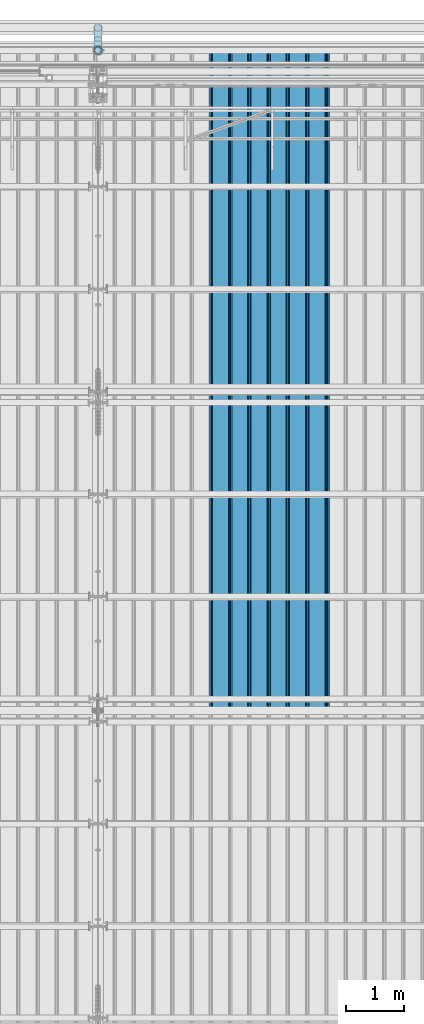
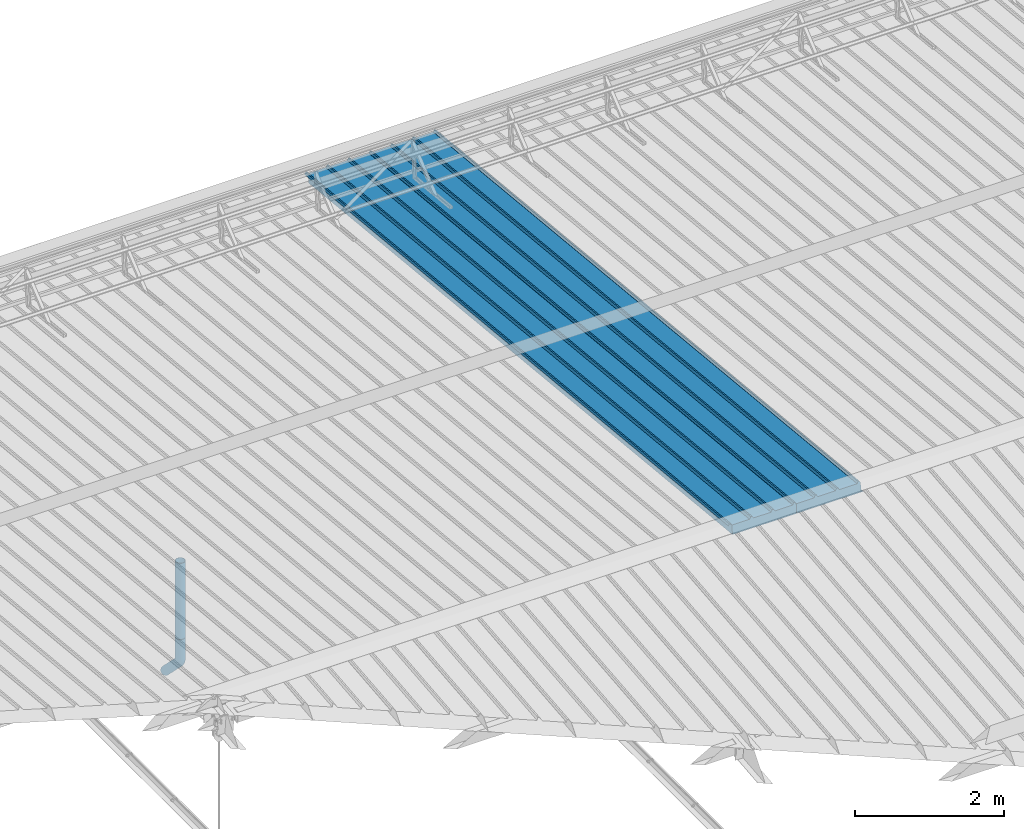
# One storey, part 60 of 709: 4 beams, 4 elements without a shape of their own.
"""IFC4 building model written with IfcOpenShell, lengths in millimetres."""

from ifc_helpers import new_model, entity, si_unit, direction, frame, origin_with_axes, place, context, subcontext, project, spatial, line, indexed_curve, outline, extrude, material, element, aggregate, save


model = new_model("IFC4")

# Units and contexts
model_context = context("Model", 3, precision=0.2, world=origin_with_axes(), true_north=direction((0.0, 1.0)))
body_context = subcontext(model_context, "Body", "Model", "MODEL_VIEW")
ifc_project = project(units=[si_unit("LENGTHUNIT", "METRE", prefix="MILLI"), si_unit("AREAUNIT", "SQUARE_METRE"), si_unit("VOLUMEUNIT", "CUBIC_METRE"), si_unit("MASSUNIT", "GRAM", prefix="KILO"), si_unit("TIMEUNIT", "SECOND"), si_unit("PLANEANGLEUNIT", "RADIAN"), si_unit("SOLIDANGLEUNIT", "STERADIAN"), si_unit("THERMODYNAMICTEMPERATUREUNIT", "DEGREE_CELSIUS"), si_unit("LUMINOUSINTENSITYUNIT", "LUMEN")], contexts=[model_context])

# Site, building, storey
site_placement = place(None, origin_with_axes())
site = spatial("IfcSite", under=ifc_project, at=site_placement, CompositionType="ELEMENT")
building_placement = place(site_placement, origin_with_axes())
building = spatial("IfcBuilding", under=site, at=building_placement, Name="Undefined", CompositionType="ELEMENT")
storey_placement = place(building_placement, origin_with_axes())
storey = spatial("IfcBuildingStorey", under=building, at=storey_placement, Name="Undefined", CompositionType="ELEMENT", Elevation=0.0)

# Assembly, beam
assembly_1_placement = place(storey_placement, frame((25452.44, 11009.10459, 8419.96887), z_axis=(1.0, 0.0, 0.0), x_axis=(0.0, 0.9950371902, -0.099503719)))
assembly_1 = element("IfcElementAssembly", 1, at=assembly_1_placement, inside=storey)
ifc_material_1 = material(Name="Insulation", Category="Insulation")
beam_1_placement = place(assembly_1_placement, origin_with_axes())
beam_1 = element("IfcBeam", 2, at=beam_1_placement, material=ifc_material_1, ObjectType="P-99", context=body_context, shape_type="SolidModel", body=[
    extrude(outline(indexed_curve([(-509.8453, 89.5), (-490.1547, 89.5), (-471.67949, 57.5), (-471.67949, -88.5), (-436.67949, -88.5), (-436.67949, -91.5), (562.55841, -91.5), (562.55841, -89.5), (527.55841, -89.5), (527.55841, 57.5), (510.2379, 88.5), (489.7621, 88.5), (472.44159, 58.5), (196.71923, 58.5), (177.66667, 91.5), (155.66667, 91.5), (136.61411, 58.5), (-136.61411, 58.5), (-155.66667, 91.5), (-177.66667, 91.5), (-196.71923, 58.5), (-469.94744, 58.5), (-489.0, 91.5), (-511.0, 91.5), (-527.16581, 63.5), (-525.43376, 62.5)], segments=[line(1, 2, 3, 4, 5, 6, 7, 8, 9, 10, 11, 12, 13, 14, 15, 16, 17, 18, 19, 20, 21, 22, 23, 24, 25, 26, 1)])), frame((0.0, 0.0, 0.0), z_axis=(-1.0, 0.0, 0.0), x_axis=(0.0, 0.0, 1.0)), (0.0, 0.0, -1.0), 11459.0),
])
aggregate(assembly_1, [beam_1])

assembly_2_placement = place(storey_placement, frame((24452.44, 11009.10459, 8419.96887), z_axis=(1.0, 0.0, 0.0), x_axis=(0.0, 0.9950371902, -0.099503719)))
assembly_2 = element("IfcElementAssembly", 3, at=assembly_2_placement, inside=storey)
beam_2_placement = place(assembly_2_placement, origin_with_axes())
beam_2 = element("IfcBeam", 4, at=beam_2_placement, material=ifc_material_1, ObjectType="P-99", context=body_context, shape_type="SolidModel", body=[
    extrude(outline(indexed_curve([(-509.8453, 89.5), (-490.1547, 89.5), (-471.67949, 57.5), (-471.67949, -88.5), (-436.67949, -88.5), (-436.67949, -91.5), (562.55841, -91.5), (562.55841, -89.5), (527.55841, -89.5), (527.55841, 57.5), (510.2379, 88.5), (489.7621, 88.5), (472.44159, 58.5), (196.71923, 58.5), (177.66667, 91.5), (155.66667, 91.5), (136.61411, 58.5), (-136.61411, 58.5), (-155.66667, 91.5), (-177.66667, 91.5), (-196.71923, 58.5), (-469.94744, 58.5), (-489.0, 91.5), (-511.0, 91.5), (-527.16581, 63.5), (-525.43376, 62.5)], segments=[line(1, 2, 3, 4, 5, 6, 7, 8, 9, 10, 11, 12, 13, 14, 15, 16, 17, 18, 19, 20, 21, 22, 23, 24, 25, 26, 1)])), frame((0.0, 0.0, 0.0), z_axis=(-1.0, 0.0, 0.0), x_axis=(0.0, 0.0, 1.0)), (0.0, 0.0, -1.0), 11459.0),
])
aggregate(assembly_2, [beam_2])

assembly_3_placement = place(storey_placement, frame((22000.0, 22420.0, 1676.92297), z_axis=(0.0, -1.0, 0.0), x_axis=(0.0, 0.0, -1.0)))
assembly_3 = element("IfcElementAssembly", 5, at=assembly_3_placement, inside=storey)
ifc_material_2 = material(Name="Steel_Undefined", Category="STEEL")
beam_3_placement = place(assembly_3_placement, origin_with_axes())
beam_3 = element("IfcBeam", 6, at=beam_3_placement, material=ifc_material_2, ObjectType="614", context=body_context, shape_type="SolidModel", body=[
    extrude(outline(indexed_curve([(70.0, 0.0), (69.61653, 7.31699), (68.47033, 14.55382), (66.57396, 21.63119), (63.94818, 28.47157), (60.62178, 35.0), (56.63119, 41.14497), (52.02014, 46.83914), (46.83914, 52.02014), (41.14497, 56.63119), (35.0, 60.62178), (28.47157, 63.94818), (21.63119, 66.57396), (14.55382, 68.47033), (7.31699, 69.61653), (0.0, 70.0), (-7.31699, 69.61653), (-14.55382, 68.47033), (-21.63119, 66.57396), (-28.47157, 63.94818), (-35.0, 60.62178), (-41.14497, 56.63119), (-46.83914, 52.02014), (-52.02014, 46.83914), (-56.63119, 41.14497), (-60.62178, 35.0), (-63.94818, 28.47157), (-66.57396, 21.63119), (-68.47033, 14.55382), (-69.61653, 7.31699), (-70.0, 0.0), (-69.61653, -7.31699), (-68.47033, -14.55382), (-66.57396, -21.63119), (-63.94818, -28.47157), (-60.62178, -35.0), (-56.63119, -41.14497), (-52.02014, -46.83914), (-46.83914, -52.02014), (-41.14497, -56.63119), (-35.0, -60.62178), (-28.47157, -63.94818), (-21.63119, -66.57396), (-14.55382, -68.47033), (-7.31699, -69.61653), (0.0, -70.0), (7.31699, -69.61653), (14.55382, -68.47033), (21.63119, -66.57396), (28.47157, -63.94818), (35.0, -60.62178), (41.14497, -56.63119), (46.83914, -52.02014), (52.02014, -46.83914), (56.63119, -41.14497), (60.62178, -35.0), (63.94818, -28.47157), (66.57396, -21.63119), (68.47033, -14.55382), (69.61653, -7.31699)], segments=[line(1, 2, 3, 4, 5, 6, 7, 8, 9, 10, 11, 12, 13, 14, 15, 16, 17, 18, 19, 20, 21, 22, 23, 24, 25, 26, 27, 28, 29, 30, 31, 32, 33, 34, 35, 36, 37, 38, 39, 40, 41, 42, 43, 44, 45, 46, 47, 48, 49, 50, 51, 52, 53, 54, 55, 56, 57, 58, 59, 60, 1)]), holes=[indexed_curve([(65.0, 0.0), (64.64392, -6.79435), (63.57959, -13.51426), (61.81867, -20.0861), (59.38045, -26.43788), (56.29165, -32.5), (52.5861, -38.20604), (48.30441, -43.49349), (43.49349, -48.30441), (38.20604, -52.5861), (32.5, -56.29165), (26.43788, -59.38045), (20.0861, -61.81867), (13.51426, -63.57959), (6.79435, -64.64392), (0.0, -65.0), (-6.79435, -64.64392), (-13.51426, -63.57959), (-20.0861, -61.81867), (-26.43788, -59.38045), (-32.5, -56.29165), (-38.20604, -52.5861), (-43.49349, -48.30441), (-48.30441, -43.49349), (-52.5861, -38.20604), (-56.29165, -32.5), (-59.38045, -26.43788), (-61.81867, -20.0861), (-63.57959, -13.51426), (-64.64392, -6.79435), (-65.0, 0.0), (-64.64392, 6.79435), (-63.57959, 13.51426), (-61.81867, 20.0861), (-59.38045, 26.43788), (-56.29165, 32.5), (-52.5861, 38.20604), (-48.30441, 43.49349), (-43.49349, 48.30441), (-38.20604, 52.5861), (-32.5, 56.29165), (-26.43788, 59.38045), (-20.0861, 61.81867), (-13.51426, 63.57959), (-6.79435, 64.64392), (0.0, 65.0), (6.79435, 64.64392), (13.51426, 63.57959), (20.0861, 61.81867), (26.43788, 59.38045), (32.5, 56.29165), (38.20604, 52.5861), (43.49349, 48.30441), (48.30441, 43.49349), (52.5861, 38.20604), (56.29165, 32.5), (59.38045, 26.43788), (61.81867, 20.0861), (63.57959, 13.51426), (64.64392, 6.79435)], segments=[line(1, 2, 3, 4, 5, 6, 7, 8, 9, 10, 11, 12, 13, 14, 15, 16, 17, 18, 19, 20, 21, 22, 23, 24, 25, 26, 27, 28, 29, 30, 31, 32, 33, 34, 35, 36, 37, 38, 39, 40, 41, 42, 43, 44, 45, 46, 47, 48, 49, 50, 51, 52, 53, 54, 55, 56, 57, 58, 59, 60, 1)])]), frame((0.0, 0.0, 0.0), z_axis=(-1.0, 0.0, 0.0), x_axis=(0.0, 0.0, 1.0)), (0.0, 0.0, -1.0), 1250.0),
])
aggregate(assembly_3, [beam_3])

assembly_4_placement = place(storey_placement, frame((22000.0, 22420.0, 526.92297), z_axis=(1.0, 0.0, 0.0), x_axis=(0.0, 0.0, -1.0)))
assembly_4 = element("IfcElementAssembly", 7, at=assembly_4_placement, inside=storey)
beam_4_placement = place(assembly_4_placement, origin_with_axes())
beam_4 = element("IfcBeam", 8, at=beam_4_placement, material=ifc_material_2, ObjectType="617", context=body_context, shape_type="SolidModel", body=[
    entity("IfcSweptDiskSolid", entity("IfcIndexedPolyCurve", entity("IfcCartesianPointList3D", [[0.0, 0.0, 0.0], [448.2233, 0.0, 0.0], [496.05873, 9.51506, 0.0], [536.61165, 36.61165, 0.0], [900.0, 400.0, 0.0]]), [entity("IfcLineIndex", [1, 2]), entity("IfcArcIndex", [2, 3, 4]), entity("IfcLineIndex", [4, 5])]), 70.0, 65.0),
])
aggregate(assembly_4, [beam_4])

save(model, "model.ifc")
